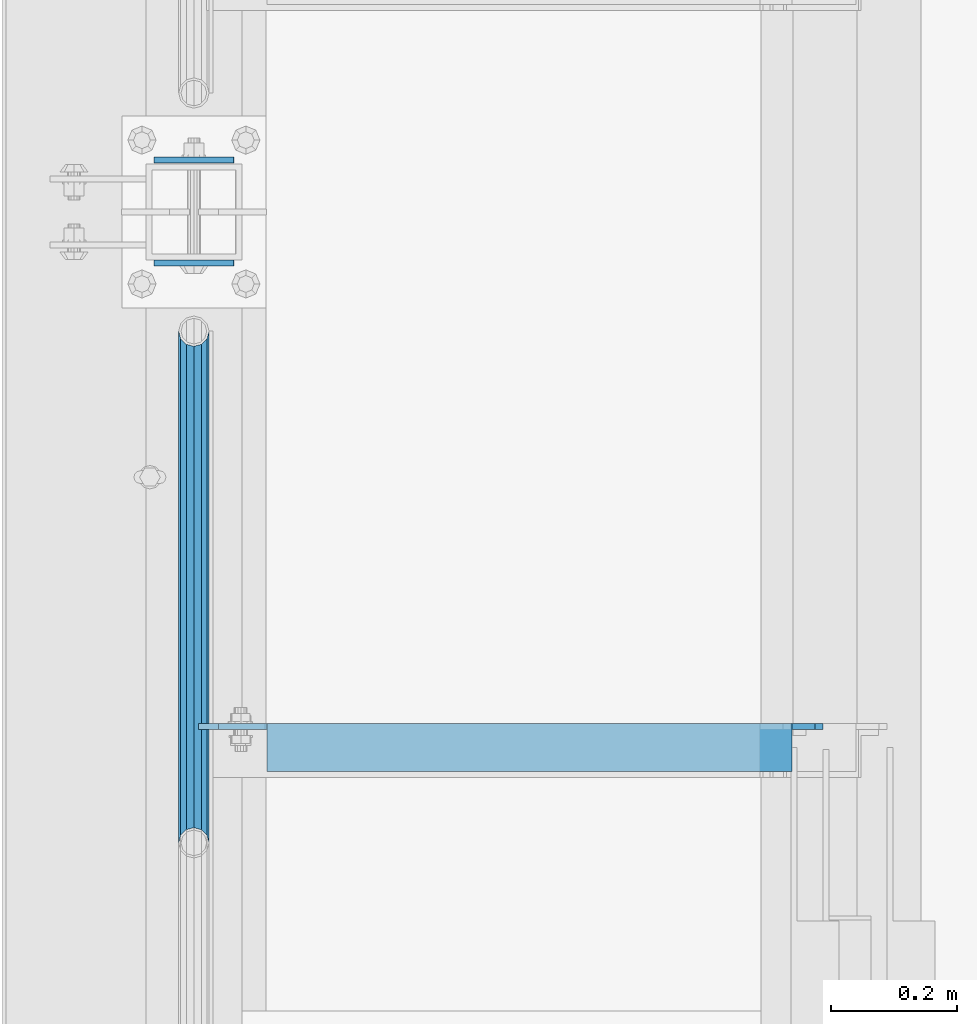
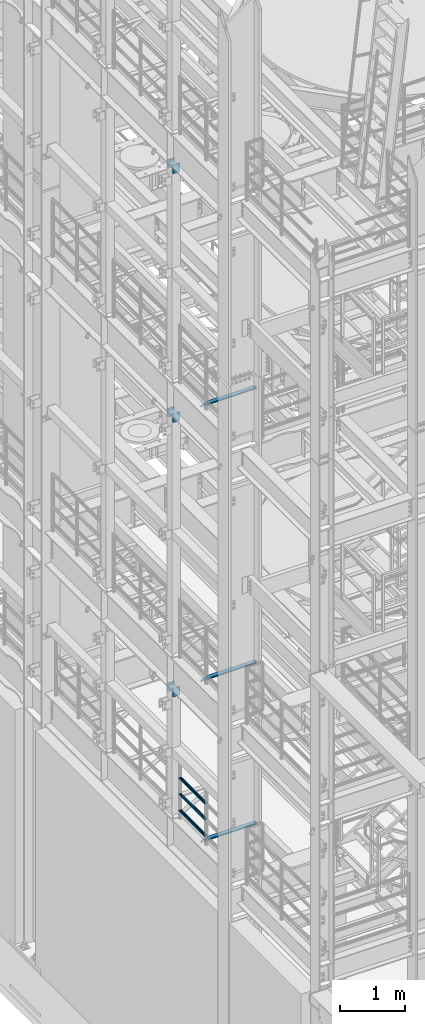
# One storey, part 1180 of 1876: 12 beams, 7 elements without a shape of their own.
"""IFC2X3 building model written with IfcOpenShell, lengths in millimetres."""

from ifc_helpers import new_model, si_unit, frame, origin_with_axes, place, context, subcontext, project, spatial, faceted_brep, material, type_object, element, aggregate, save


model = new_model("IFC2X3")

# Units and contexts
model_context = context("Model", 3, precision=1e-05, world=origin_with_axes())
body_context = subcontext(model_context, "Body", "Model", "MODEL_VIEW")
ifc_project = project(units=[si_unit("LENGTHUNIT", "METRE", prefix="MILLI"), si_unit("AREAUNIT", "SQUARE_METRE"), si_unit("VOLUMEUNIT", "CUBIC_METRE"), si_unit("MASSUNIT", "GRAM", prefix="KILO"), si_unit("TIMEUNIT", "SECOND"), si_unit("PLANEANGLEUNIT", "RADIAN"), si_unit("SOLIDANGLEUNIT", "STERADIAN"), si_unit("THERMODYNAMICTEMPERATUREUNIT", "DEGREE_CELSIUS"), si_unit("LUMINOUSINTENSITYUNIT", "LUMEN")], contexts=[model_context])

# Site, building, storey
site_placement = place(None, origin_with_axes())
site = spatial("IfcSite", under=ifc_project, at=site_placement, CompositionType="ELEMENT")
building_placement = place(site_placement, origin_with_axes())
building = spatial("IfcBuilding", under=site, at=building_placement, Name="Undefined", CompositionType="ELEMENT")
storey_placement = place(building_placement, origin_with_axes())
storey = spatial("IfcBuildingStorey", under=building, at=storey_placement, Name="Undefined", CompositionType="ELEMENT", Elevation=0.0)

# Assembly, beams
assembly_1_placement = place(storey_placement, origin_with_axes())
assembly_1 = element("IfcElementAssembly", 1, at=assembly_1_placement, inside=storey, Name="RAIL", AssemblyPlace="NOTDEFINED", PredefinedType="RIGID_FRAME")
ifc_material_1 = material()
beam_type_1 = type_object("IfcBeamType", Name="PIPE1-1/2SCH40", PredefinedType="NOTDEFINED")
beam_1_placement = place(assembly_1_placement, frame((5.37416779650463e-12, -2729.3062, 5292.725), z_axis=(0.0, 0.0, 1.0), x_axis=(0.0, -1.0, 0.0)))
beam_1 = element("IfcBeam", 2, at=beam_1_placement, type_object=beam_type_1, material=ifc_material_1, Name="RAIL", ObjectType="PIPE1-1/2SCH40", context=body_context, shape_type="Brep", body=[
    faceted_brep([(792.499707006684, -12.0649999999996, 20.8971929933177), (792.499707006684, -12.0650000000314, 15.8661214311469), (792.006278568813, -10.2235000000001, 17.7076214311819), (789.266900000001, -9.09494701772928e-13, 20.4470000000001), (789.266900000001, -9.09494701772928e-13, 24.130000000001), (792.00627856883, 10.2235000000001, 17.7076214311819), (792.499707006684, 12.0649999999678, 15.8661214312124), (792.499707006684, 12.0649999999996, 20.8971929933177), (813.396900000002, 24.1300000000001, 0.0), (801.331900000001, 20.8971929933186, 12.0649999999987), (801.331900000001, 20.8971929933186, -12.0649999999987), (798.142328437896, 17.7076214311801, 10.2235000000001), (800.881707006714, 20.4470000000001, 0.0), (798.142328437896, 17.7076214311801, -10.2235000000001), (792.499707006684, 12.0649999999678, -15.8661214312124), (792.499707006684, 12.0649999999996, -20.8971929933177), (792.00627856883, 10.2235000000001, -17.7076214311819), (789.266900000001, 0.0, -20.4470000000001), (789.266900000001, 0.0, -24.130000000001), (792.499707006684, -12.0650000000314, -15.8661214311469), (792.499707006684, -12.0649999999996, -20.8971929933177), (792.006278568813, -10.2235000000001, -17.7076214311819), (813.396900000002, -24.1300000000319, 0.0), (801.331900000001, -20.8971929933186, -12.0649999999987), (801.331900000001, -20.8971929933186, 12.0649999999987), (798.142328437831, -17.7076214311801, -10.2235000000001), (800.881707006651, -20.4470000000001, 0.0), (798.142328437831, -17.7076214311801, 10.2235000000001), (12.0650000000064, -20.8971929933177, -12.0649999999987), (20.8971929933249, -12.0650000000005, -20.8971929933177), (0.0, 24.1299999999992, 0.0), (12.0650000000064, 20.8971929933177, -12.0649999999987), (12.0650000000064, 20.8971929933177, 12.0649999999987), (20.8971929933249, 12.0650000000005, 20.8971929933177), (24.1300000000064, 0.0, 24.130000000001), (20.8971929933249, 12.0650000000005, -20.8971929933177), (24.1300000000063, 0.0, -24.130000000001), (24.1300000000063, 0.0, -20.4470000000001), (20.8971929933249, -12.0650000000005, -15.8661214311796), (21.3906214311868, -10.2235000000001, -17.7076214311819), (21.3906214311868, 10.2235000000001, -17.7076214311819), (20.8971929933249, 12.0650000000005, -15.8661214311796), (15.2545715621445, 17.7076214311801, -10.2235000000001), (12.5151929933249, 20.4470000000001, 0.0), (15.2545715621445, 17.7076214311801, 10.2235000000001), (20.8971929933249, 12.0650000000005, 15.8661214311796), (21.3906214311868, 10.2235000000001, 17.7076214311819), (24.1300000000064, 0.0, 20.4470000000001), (21.3906214311868, -10.2235000000001, 17.7076214311819), (20.8971929933249, -12.0650000000005, 15.8661214311796), (20.8971929933249, -12.0650000000005, 20.8971929933177), (12.0650000000064, -20.8971929933177, 12.0649999999987), (0.0, -24.1299999999992, 0.0), (15.2545715621445, -17.7076214311801, 10.2235000000001), (12.5151929933249, -20.4470000000001, 0.0), (15.2545715621445, -17.7076214311801, -10.2235000000001)], [[[0, 1, 2, 3, 4]], [[4, 3, 5, 6, 7]], [[8, 9, 10]], [[7, 6, 11, 12, 13, 14, 15, 10, 9]], [[16, 17, 18, 15, 14]], [[19, 20, 18, 17, 21]], [[22, 23, 24]], [[24, 23, 20, 19, 25, 26, 27, 1, 0]], [[28, 29, 20, 23]], [[30, 31, 32]], [[33, 34, 4, 7]], [[32, 33, 7, 9]], [[30, 32, 9, 8]], [[31, 30, 8, 10]], [[35, 31, 10, 15]], [[36, 35, 15, 18]], [[29, 36, 18, 20]], [[37, 36, 29, 38, 39]], [[40, 41, 35, 36, 37]], [[32, 31, 35, 41, 42, 43, 44, 45, 33]], [[33, 45, 46, 47, 34]], [[34, 47, 48, 49, 50]], [[34, 50, 0, 4]], [[50, 51, 24, 0]], [[51, 52, 22, 24]], [[52, 28, 23, 22]], [[51, 28, 52]], [[50, 49, 53, 54, 55, 38, 29, 28, 51]], [[55, 54, 26, 25]], [[21, 39, 38, 55, 25, 19]], [[37, 39, 21, 17]], [[40, 37, 17, 16]], [[42, 41, 40, 16, 14, 13]], [[43, 42, 13, 12]], [[44, 43, 12, 11]], [[5, 46, 45, 44, 11, 6]], [[47, 46, 5, 3]], [[48, 47, 3, 2]], [[53, 49, 48, 2, 1, 27]], [[54, 53, 27, 26]]]),
])
beam_2_placement = place(assembly_1_placement, frame((-1.81898940354586e-12, -3542.7031, 5597.525), z_axis=(0.0, 0.0, -1.0), x_axis=(0.0, 1.0, 0.0)))
beam_2 = element("IfcBeam", 3, at=beam_2_placement, type_object=beam_type_1, material=ifc_material_1, Name="RAIL", ObjectType="PIPE1-1/2SCH40", context=body_context, shape_type="Brep", body=[
    faceted_brep([(0.0, 24.1299999999992, 0.0), (12.0650000000064, 20.8971929933177, -12.0649999999987), (12.0650000000064, 20.8971929933177, 12.0649999999987), (12.0650000000064, -20.8971929933177, 12.0649999999987), (12.0650000000064, -20.8971929933177, -12.0649999999987), (0.0, -24.1299999999992, 0.0), (20.8971929933249, -12.0650000000005, 20.8971929933177), (20.8971929933249, -12.0650000000005, 15.8661214311796), (15.2545715621445, -17.7076214311801, 10.2235000000001), (12.5151929933249, -20.4470000000001, 0.0), (15.2545715621445, -17.7076214311801, -10.2235000000001), (20.8971929933249, -12.0650000000005, -15.8661214311796), (20.8971929933249, -12.0650000000005, -20.8971929933177), (24.1300000000063, 0.0, -20.4470000000001), (24.1300000000063, 0.0, -24.130000000001), (21.3906214311868, -10.2235000000001, -17.7076214311819), (21.3906214311868, 10.2235000000001, -17.7076214311819), (20.8971929933249, 12.0650000000005, -15.8661214311796), (20.8971929933249, 12.0650000000005, -20.8971929933177), (15.2545715621445, 17.7076214311801, -10.2235000000001), (12.5151929933249, 20.4470000000001, 0.0), (15.2545715621445, 17.7076214311801, 10.2235000000001), (20.8971929933249, 12.0650000000005, 15.8661214311796), (20.8971929933249, 12.0650000000005, 20.8971929933177), (21.3906214311868, 10.2235000000001, 17.7076214311819), (24.1300000000064, 0.0, 20.4470000000001), (24.1300000000064, 0.0, 24.130000000001), (21.3906214311868, -10.2235000000001, 17.7076214311819), (813.396900000002, 24.1300000000001, 0.0), (801.331900000001, 20.8971929933186, -12.0649999999987), (792.499707006684, 12.0649999999996, -20.8971929933177), (813.396900000002, -24.1300000000319, 0.0), (801.331900000001, -20.8971929933186, -12.0649999999987), (801.331900000001, -20.8971929933186, 12.0649999999987), (792.499707006684, -12.0649999999996, 20.8971929933177), (792.499707006684, -12.0649999999996, -20.8971929933177), (789.266900000001, 0.0, -24.130000000001), (792.00627856883, 10.2235000000001, -17.7076214311819), (789.266900000001, 0.0, -20.4470000000001), (792.499707006684, 12.0649999999678, -15.8661214312124), (792.499707006684, -12.0650000000314, -15.8661214311469), (792.006278568813, -10.2235000000001, -17.7076214311819), (798.142328437831, -17.7076214311801, -10.2235000000001), (800.881707006651, -20.4470000000001, 0.0), (798.142328437831, -17.7076214311801, 10.2235000000001), (792.499707006684, -12.0650000000314, 15.8661214311469), (792.006278568813, -10.2235000000001, 17.7076214311819), (789.266900000001, -9.09494701772928e-13, 20.4470000000001), (789.266900000001, -9.09494701772928e-13, 24.130000000001), (792.499707006684, 12.0649999999996, 20.8971929933177), (801.331900000001, 20.8971929933186, 12.0649999999987), (792.499707006684, 12.0649999999678, 15.8661214312124), (798.142328437896, 17.7076214311801, 10.2235000000001), (800.881707006714, 20.4470000000001, 0.0), (798.142328437896, 17.7076214311801, -10.2235000000001), (792.00627856883, 10.2235000000001, 17.7076214311819)], [[[0, 1, 2]], [[3, 4, 5]], [[6, 7, 8, 9, 10, 11, 12, 4, 3]], [[13, 14, 12, 11, 15]], [[16, 17, 18, 14, 13]], [[2, 1, 18, 17, 19, 20, 21, 22, 23]], [[23, 22, 24, 25, 26]], [[26, 25, 27, 7, 6]], [[1, 0, 28, 29]], [[18, 1, 29, 30]], [[31, 32, 33]], [[6, 3, 33, 34]], [[3, 5, 31, 33]], [[5, 4, 32, 31]], [[4, 12, 35, 32]], [[12, 14, 36, 35]], [[14, 18, 30, 36]], [[37, 38, 36, 30, 39]], [[40, 35, 36, 38, 41]], [[33, 32, 35, 40, 42, 43, 44, 45, 34]], [[34, 45, 46, 47, 48]], [[26, 6, 34, 48]], [[2, 23, 49, 50]], [[23, 26, 48, 49]], [[0, 2, 50, 28]], [[28, 50, 29]], [[49, 51, 52, 53, 54, 39, 30, 29, 50]], [[48, 47, 55, 51, 49]], [[25, 24, 55, 47]], [[55, 24, 22, 21, 52, 51]], [[21, 20, 53, 52]], [[20, 19, 54, 53]], [[19, 17, 16, 37, 39, 54]], [[16, 13, 38, 37]], [[13, 15, 41, 38]], [[41, 15, 11, 10, 42, 40]], [[10, 9, 43, 42]], [[9, 8, 44, 43]], [[8, 7, 27, 46, 45, 44]], [[27, 25, 47, 46]]]),
])
beam_3_placement = place(assembly_1_placement, frame((-1.81898940354586e-12, -3542.7031, 5902.325), z_axis=(0.0, 0.0, -1.0), x_axis=(0.0, 1.0, 0.0)))
beam_3 = element("IfcBeam", 4, at=beam_3_placement, type_object=beam_type_1, material=ifc_material_1, Name="RAIL", ObjectType="PIPE1-1/2SCH40", context=body_context, shape_type="Brep", body=[
    faceted_brep([(0.0, 24.1299999999992, 0.0), (12.0650000000064, 20.8971929933177, -12.0649999999987), (12.0650000000064, 20.8971929933177, 12.0649999999987), (12.0650000000064, -20.8971929933177, 12.0649999999987), (12.0650000000064, -20.8971929933177, -12.0649999999987), (0.0, -24.1299999999992, 0.0), (20.8971929933249, -12.0650000000005, 20.8971929933177), (20.8971929933249, -12.0650000000005, 15.8661214311796), (15.2545715621445, -17.7076214311801, 10.2235000000001), (12.5151929933249, -20.4470000000001, 0.0), (15.2545715621445, -17.7076214311801, -10.2235000000001), (20.8971929933249, -12.0650000000005, -15.8661214311796), (20.8971929933249, -12.0650000000005, -20.8971929933177), (24.1300000000063, 0.0, -20.4470000000001), (24.1300000000063, 0.0, -24.130000000001), (21.3906214311868, -10.2235000000001, -17.7076214311819), (21.3906214311868, 10.2235000000001, -17.7076214311819), (20.8971929933249, 12.0650000000005, -15.8661214311796), (20.8971929933249, 12.0650000000005, -20.8971929933177), (15.2545715621445, 17.7076214311801, -10.2235000000001), (12.5151929933249, 20.4470000000001, 0.0), (15.2545715621445, 17.7076214311801, 10.2235000000001), (20.8971929933249, 12.0650000000005, 15.8661214311796), (20.8971929933249, 12.0650000000005, 20.8971929933177), (21.3906214311868, 10.2235000000001, 17.7076214311819), (24.1300000000064, 0.0, 20.4470000000001), (24.1300000000064, 0.0, 24.130000000001), (21.3906214311868, -10.2235000000001, 17.7076214311819), (813.396900000002, 24.1300000000001, 0.0), (801.331900000001, 20.8971929933186, -12.0649999999987), (792.499707006684, 12.0649999999996, -20.8971929933177), (813.396900000002, -24.1300000000319, 0.0), (801.331900000001, -20.8971929933186, -12.0649999999987), (801.331900000001, -20.8971929933186, 12.0649999999987), (792.499707006684, -12.0649999999996, 20.8971929933177), (792.499707006684, -12.0649999999996, -20.8971929933177), (789.266900000001, 0.0, -24.130000000001), (792.00627856883, 10.2235000000001, -17.7076214311819), (789.266900000001, 0.0, -20.4470000000001), (792.499707006684, 12.0649999999678, -15.8661214312124), (792.499707006684, -12.0650000000314, -15.8661214311469), (792.006278568813, -10.2235000000001, -17.7076214311819), (798.142328437831, -17.7076214311801, -10.2235000000001), (800.881707006651, -20.4470000000001, 0.0), (798.142328437831, -17.7076214311801, 10.2235000000001), (792.499707006684, -12.0650000000314, 15.8661214311469), (792.006278568813, -10.2235000000001, 17.7076214311819), (789.266900000001, -9.09494701772928e-13, 20.4470000000001), (789.266900000001, -9.09494701772928e-13, 24.130000000001), (792.499707006684, 12.0649999999996, 20.8971929933177), (801.331900000001, 20.8971929933186, 12.0649999999987), (792.499707006684, 12.0649999999678, 15.8661214312124), (798.142328437896, 17.7076214311801, 10.2235000000001), (800.881707006714, 20.4470000000001, 0.0), (798.142328437896, 17.7076214311801, -10.2235000000001), (792.00627856883, 10.2235000000001, 17.7076214311819)], [[[0, 1, 2]], [[3, 4, 5]], [[6, 7, 8, 9, 10, 11, 12, 4, 3]], [[13, 14, 12, 11, 15]], [[16, 17, 18, 14, 13]], [[2, 1, 18, 17, 19, 20, 21, 22, 23]], [[23, 22, 24, 25, 26]], [[26, 25, 27, 7, 6]], [[1, 0, 28, 29]], [[18, 1, 29, 30]], [[31, 32, 33]], [[6, 3, 33, 34]], [[3, 5, 31, 33]], [[5, 4, 32, 31]], [[4, 12, 35, 32]], [[12, 14, 36, 35]], [[14, 18, 30, 36]], [[37, 38, 36, 30, 39]], [[40, 35, 36, 38, 41]], [[33, 32, 35, 40, 42, 43, 44, 45, 34]], [[34, 45, 46, 47, 48]], [[26, 6, 34, 48]], [[2, 23, 49, 50]], [[23, 26, 48, 49]], [[0, 2, 50, 28]], [[28, 50, 29]], [[49, 51, 52, 53, 54, 39, 30, 29, 50]], [[48, 47, 55, 51, 49]], [[25, 24, 55, 47]], [[55, 24, 22, 21, 52, 51]], [[21, 20, 53, 52]], [[20, 19, 54, 53]], [[19, 17, 16, 37, 39, 54]], [[16, 13, 38, 37]], [[13, 15, 41, 38]], [[41, 15, 11, 10, 42, 40]], [[10, 9, 43, 42]], [[9, 8, 44, 43]], [[8, 7, 27, 46, 45, 44]], [[27, 25, 47, 46]]]),
])
aggregate(assembly_1, [beam_1, beam_2, beam_3])

assembly_2_placement = place(storey_placement, origin_with_axes())
assembly_2 = element("IfcElementAssembly", 5, at=assembly_2_placement, inside=storey, Name="BEAM", AssemblyPlace="NOTDEFINED", PredefinedType="RIGID_FRAME")
ifc_material_2 = material(Name="STEEL/A36")
beam_type_2 = type_object("IfcBeamType", PredefinedType="NOTDEFINED")
beam_4_placement = place(assembly_2_placement, frame((-63.6296757345187, -2457.45, 7448.54714244377), z_axis=(5.59490000219896e-05, 0.0, -0.999999998434855), x_axis=(0.999999998434855, 0.0, 5.59490000219868e-05)))
beam_4 = element("IfcBeam", 6, at=beam_4_placement, type_object=beam_type_2, material=ifc_material_2, Name="PLATE", context=body_context, shape_type="Brep", body=[
    faceted_brep([(0.0, 4.76249999999982, -82.5499999999993), (0.0, 4.76249999999982, 82.5499999999993), (127.0, 4.76249999999982, 82.5499999999993), (127.0, 4.76249999999982, -82.5499999999993), (0.0, -4.76249999999982, 82.5499999999993), (127.0, -4.76249999999982, 82.5499999999993), (0.0, -4.76249999999982, -82.5499999999993), (127.0, -4.76249999999982, -82.5499999999993)], [[[0, 1, 2, 3]], [[1, 4, 5, 2]], [[4, 6, 7, 5]], [[6, 0, 3, 7]], [[5, 7, 3, 2]], [[6, 4, 1, 0]]]),
])
beam_5_placement = place(assembly_2_placement, frame((-63.6296757345187, -2620.9625, 7448.54714244377), z_axis=(5.59490000219896e-05, 0.0, -0.999999998434855), x_axis=(0.999999998434855, 0.0, 5.59490000219868e-05)))
beam_5 = element("IfcBeam", 7, at=beam_5_placement, type_object=beam_type_2, material=ifc_material_2, Name="PLATE", context=body_context, shape_type="Brep", body=[
    faceted_brep([(0.0, 4.76249999999982, -82.5499999999993), (0.0, 4.76249999999982, 82.5499999999993), (127.0, 4.76249999999982, 82.5499999999993), (127.0, 4.76249999999982, -82.5499999999993), (0.0, -4.76249999999982, 82.5499999999993), (127.0, -4.76249999999982, 82.5499999999993), (0.0, -4.76249999999982, -82.5499999999993), (127.0, -4.76249999999982, -82.5499999999993)], [[[0, 1, 2, 3]], [[1, 4, 5, 2]], [[4, 6, 7, 5]], [[6, 0, 3, 7]], [[5, 7, 3, 2]], [[6, 4, 1, 0]]]),
])
aggregate(assembly_2, [beam_4, beam_5])

assembly_3_placement = place(storey_placement, origin_with_axes())
assembly_3 = element("IfcElementAssembly", 8, at=assembly_3_placement, inside=storey, Name="BEAM", AssemblyPlace="NOTDEFINED", PredefinedType="RIGID_FRAME")
beam_6_placement = place(assembly_3_placement, frame((-63.6315195800257, -2457.45, 12604.7488224823), z_axis=(2.95459999824743e-05, 0.0, -0.999999999563517), x_axis=(0.999999999563517, 0.0, 2.95459999828704e-05)))
beam_6 = element("IfcBeam", 9, at=beam_6_placement, type_object=beam_type_2, material=ifc_material_2, Name="PLATE", context=body_context, shape_type="Brep", body=[
    faceted_brep([(0.0, 4.76249999999982, -82.5499999999993), (0.0, 4.76249999999982, 82.5499999999993), (127.0, 4.76249999999982, 82.5499999999993), (127.0, 4.76249999999982, -82.5499999999993), (0.0, -4.76249999999982, 82.5499999999993), (127.0, -4.76249999999982, 82.5499999999993), (0.0, -4.76249999999982, -82.5499999999993), (127.0, -4.76249999999982, -82.5499999999993)], [[[0, 1, 2, 3]], [[1, 4, 5, 2]], [[4, 6, 7, 5]], [[6, 0, 3, 7]], [[5, 7, 3, 2]], [[6, 4, 1, 0]]]),
])
beam_7_placement = place(assembly_3_placement, frame((-63.6315195800257, -2620.9625, 12604.7488224823), z_axis=(2.95459999824743e-05, 0.0, -0.999999999563517), x_axis=(0.999999999563517, 0.0, 2.95459999828704e-05)))
beam_7 = element("IfcBeam", 10, at=beam_7_placement, type_object=beam_type_2, material=ifc_material_2, Name="PLATE", context=body_context, shape_type="Brep", body=[
    faceted_brep([(0.0, 4.76249999999982, -82.5499999999993), (0.0, 4.76249999999982, 82.5499999999993), (127.0, 4.76249999999982, 82.5499999999993), (127.0, 4.76249999999982, -82.5499999999993), (0.0, -4.76249999999982, 82.5499999999993), (127.0, -4.76249999999982, 82.5499999999993), (0.0, -4.76249999999982, -82.5499999999993), (127.0, -4.76249999999982, -82.5499999999993)], [[[0, 1, 2, 3]], [[1, 4, 5, 2]], [[4, 6, 7, 5]], [[6, 0, 3, 7]], [[5, 7, 3, 2]], [[6, 4, 1, 0]]]),
])
aggregate(assembly_3, [beam_6, beam_7])

assembly_4_placement = place(storey_placement, origin_with_axes())
assembly_4 = element("IfcElementAssembly", 11, at=assembly_4_placement, inside=storey, Name="BEAM", AssemblyPlace="NOTDEFINED", PredefinedType="RIGID_FRAME")
beam_8_placement = place(assembly_4_placement, frame((-63.5, -2457.45, 17278.35), z_axis=(0.0, 0.0, -1.0), x_axis=(1.0, 0.0, 0.0)))
beam_8 = element("IfcBeam", 12, at=beam_8_placement, type_object=beam_type_2, material=ifc_material_2, Name="PLATE", context=body_context, shape_type="Brep", body=[
    faceted_brep([(0.0, 4.76249999999982, -82.5499999999993), (0.0, 4.76249999999982, 82.5499999999993), (127.0, 4.76249999999982, 82.5499999999993), (127.0, 4.76249999999982, -82.5499999999993), (0.0, -4.76249999999982, 82.5499999999993), (127.0, -4.76249999999982, 82.5499999999993), (0.0, -4.76249999999982, -82.5499999999993), (127.0, -4.76249999999982, -82.5499999999993)], [[[0, 1, 2, 3]], [[1, 4, 5, 2]], [[4, 6, 7, 5]], [[6, 0, 3, 7]], [[5, 7, 3, 2]], [[6, 4, 1, 0]]]),
])
beam_9_placement = place(assembly_4_placement, frame((-63.5, -2620.9625, 17278.35), z_axis=(0.0, 0.0, -1.0), x_axis=(1.0, 0.0, 0.0)))
beam_9 = element("IfcBeam", 13, at=beam_9_placement, type_object=beam_type_2, material=ifc_material_2, Name="PLATE", context=body_context, shape_type="Brep", body=[
    faceted_brep([(0.0, 4.76249999999982, -82.5499999999993), (0.0, 4.76249999999982, 82.5499999999993), (127.0, 4.76249999999982, 82.5499999999993), (127.0, 4.76249999999982, -82.5499999999993), (0.0, -4.76249999999982, 82.5499999999993), (127.0, -4.76249999999982, 82.5499999999993), (0.0, -4.76249999999982, -82.5499999999993), (127.0, -4.76249999999982, -82.5499999999993)], [[[0, 1, 2, 3]], [[1, 4, 5, 2]], [[4, 6, 7, 5]], [[6, 0, 3, 7]], [[5, 7, 3, 2]], [[6, 4, 1, 0]]]),
])
aggregate(assembly_4, [beam_8, beam_9])

# Assembly, beam
assembly_5_placement = place(storey_placement, origin_with_axes())
assembly_5 = element("IfcElementAssembly", 14, at=assembly_5_placement, inside=storey, Name="ANGLE", AssemblyPlace="NOTDEFINED", PredefinedType="RIGID_FRAME")
beam_type_3 = type_object("IfcBeamType", Name="L3X3X3/8", PredefinedType="NOTDEFINED")
beam_10_placement = place(assembly_5_placement, frame((0.0, -3390.9, 8115.3), z_axis=(0.0, -1.0, 0.0), x_axis=(1.0, 0.0, 0.0)))
beam_10 = element("IfcBeam", 15, at=beam_10_placement, type_object=beam_type_3, material=ifc_material_2, Name="ANGLE", ObjectType="L3X3X3/8", context=body_context, shape_type="Brep", body=[
    faceted_brep([(115.886999817316, 28.5750000000007, 38.0999999999999), (115.886999817316, 38.0999999999985, 38.0999999999999), (115.886998826692, 38.0999999999985, -38.0999999999999), (115.88699882669, 12.699999237062, -38.0999999999999), (115.886998950515, 12.699999237062, -28.5749999999998), (115.88699895052, 28.5750000000007, -28.5749999999998), (38.8937432114558, 12.699999237062, -38.0999999999999), (38.8937433352807, 12.699999237062, -28.5749999999998), (7.14374321145577, -19.050000762938, -38.0999999999999), (7.14374333528067, -19.050000762938, -28.5749999999998), (7.1437499954859, -38.0999999999985, -38.0999999999999), (7.1437499954859, -38.0999999999985, -28.5749999999998), (1000.12500242412, 15.8750003814712, -28.5749999999998), (987.425002614851, 28.5749999999998, -28.5749999999998), (950.913000303442, 28.5749999999998, -28.5749999999998), (1000.12500001551, -38.1000000000004, -28.5749999999998), (1000.12500242412, 3.17500152588036, -28.5749999999998), (950.913001170238, 28.5749999999998, 38.0999999999999), (950.913001170238, 38.1000000000004, 38.0999999999999), (950.913000179614, 38.1000000000004, -38.0999999999999), (950.913000366403, 28.5750001907363, -38.0999999999999), (987.425002357675, 28.5750001907363, -38.0999999999999), (1000.12500216694, 15.8750003814712, -38.0999999999999), (1000.12500216694, 3.17500152588036, -38.0999999999999), (1000.12500001551, -38.1000000000004, -38.0999999999999)], [[[0, 1, 2, 3, 4, 5]], [[4, 3, 6, 7]], [[7, 6, 8, 9]], [[8, 10, 11, 9]], [[12, 13, 14, 5, 4, 7, 9, 11, 15, 16]], [[0, 5, 14, 17]], [[1, 0, 17, 18]], [[2, 1, 18, 19]], [[17, 14, 20, 19, 18]], [[13, 21, 20, 14]], [[12, 22, 21, 13]], [[16, 23, 22, 12]], [[10, 8, 6, 3, 2, 19, 20, 21, 22, 23, 24]], [[11, 10, 24, 15]], [[23, 16, 15, 24]]]),
])
aggregate(assembly_5, [beam_10])

assembly_6_placement = place(storey_placement, origin_with_axes())
assembly_6 = element("IfcElementAssembly", 16, at=assembly_6_placement, inside=storey, Name="ANGLE", AssemblyPlace="NOTDEFINED", PredefinedType="RIGID_FRAME")
beam_11_placement = place(assembly_6_placement, frame((0.0, -3390.9, 5092.7), z_axis=(0.0, -1.0, 0.0), x_axis=(1.0, 0.0, 0.0)))
beam_11 = element("IfcBeam", 17, at=beam_11_placement, type_object=beam_type_3, material=ifc_material_2, Name="ANGLE", ObjectType="L3X3X3/8", context=body_context, shape_type="Brep", body=[
    faceted_brep([(115.886999817316, 28.5750000000007, 38.0999999999999), (115.886999817316, 38.0999999999985, 38.0999999999999), (115.886998826692, 38.0999999999985, -38.0999999999999), (115.88699882669, 12.699999237062, -38.0999999999999), (115.886998950515, 12.699999237062, -28.5749999999998), (115.88699895052, 28.5750000000007, -28.5749999999998), (38.8937432114558, 12.699999237062, -38.0999999999999), (38.8937433352807, 12.699999237062, -28.5749999999998), (7.14374321145577, -19.050000762938, -38.0999999999999), (7.14374333528067, -19.050000762938, -28.5749999999998), (7.1437499954859, -38.0999999999985, -38.0999999999999), (7.1437499954859, -38.0999999999985, -28.5749999999998), (1000.12500242412, 15.8750003814712, -28.5749999999998), (987.425002614851, 28.5749999999998, -28.5749999999998), (950.913000303442, 28.5749999999998, -28.5749999999998), (1000.12500001551, -38.1000000000004, -28.5749999999998), (1000.12500242412, 3.17500152588036, -28.5749999999998), (950.913001170238, 28.5749999999998, 38.0999999999999), (950.913001170238, 38.1000000000004, 38.0999999999999), (950.913000179614, 38.1000000000004, -38.0999999999999), (950.913000366403, 28.5750001907363, -38.0999999999999), (987.425002357675, 28.5750001907363, -38.0999999999999), (1000.12500216694, 15.8750003814712, -38.0999999999999), (1000.12500216694, 3.17500152588036, -38.0999999999999), (1000.12500001551, -38.1000000000004, -38.0999999999999)], [[[0, 1, 2, 3, 4, 5]], [[4, 3, 6, 7]], [[7, 6, 8, 9]], [[8, 10, 11, 9]], [[12, 13, 14, 5, 4, 7, 9, 11, 15, 16]], [[0, 5, 14, 17]], [[1, 0, 17, 18]], [[2, 1, 18, 19]], [[17, 14, 20, 19, 18]], [[13, 21, 20, 14]], [[12, 22, 21, 13]], [[16, 23, 22, 12]], [[10, 8, 6, 3, 2, 19, 20, 21, 22, 23, 24]], [[11, 10, 24, 15]], [[23, 16, 15, 24]]]),
])
aggregate(assembly_6, [beam_11])

assembly_7_placement = place(storey_placement, origin_with_axes())
assembly_7 = element("IfcElementAssembly", 18, at=assembly_7_placement, inside=storey, Name="ANGLE", AssemblyPlace="NOTDEFINED", PredefinedType="RIGID_FRAME")
beam_12_placement = place(assembly_7_placement, frame((-1.57146639077011e-08, -3390.9, 13271.5), z_axis=(0.0, -1.0, 0.0), x_axis=(1.0, 0.0, 0.0)))
beam_12 = element("IfcBeam", 19, at=beam_12_placement, type_object=beam_type_3, material=ifc_material_2, Name="ANGLE", ObjectType="L3X3X3/8", context=body_context, shape_type="Brep", body=[
    faceted_brep([(115.886999817316, 28.5750000000007, 38.0999999999999), (115.886999817316, 38.0999999999985, 38.0999999999999), (115.886998826692, 38.0999999999985, -38.0999999999999), (115.88699882669, 12.699999237062, -38.0999999999999), (115.886998950515, 12.699999237062, -28.5749999999998), (115.88699895052, 28.5750000000007, -28.5749999999998), (38.8937432114558, 12.699999237062, -38.0999999999999), (38.8937433352807, 12.699999237062, -28.5749999999998), (7.14374321145577, -19.050000762938, -38.0999999999999), (7.14374333528067, -19.050000762938, -28.5749999999998), (7.1437499954859, -38.0999999999985, -38.0999999999999), (7.1437499954859, -38.0999999999985, -28.5749999999998), (1000.12500243948, 14.2880004882809, -28.5749999999998), (987.425002630213, 26.988000297546, -28.5749999999998), (950.913000638941, 26.988000297546, -28.5749999999998), (950.913000303442, 28.5749999999998, -28.5749999999998), (1000.12500001551, -38.1000000000004, -28.5749999999998), (1000.12500243948, 1.58799972534143, -28.5749999999998), (950.913001170238, 28.5749999999998, 38.0999999999999), (950.913001170238, 38.1000000000004, 38.0999999999999), (950.913000179614, 38.1000000000004, -38.0999999999999), (950.913000381765, 26.988000297546, -38.0999999999999), (987.425002373037, 26.988000297546, -38.0999999999999), (1000.1250021823, 14.2880004882809, -38.0999999999999), (1000.1250021823, 1.58799972534143, -38.0999999999999), (1000.12500001551, -38.1000000000004, -38.0999999999999)], [[[0, 1, 2, 3, 4, 5]], [[4, 3, 6, 7]], [[7, 6, 8, 9]], [[8, 10, 11, 9]], [[12, 13, 14, 15, 5, 4, 7, 9, 11, 16, 17]], [[0, 5, 15, 18]], [[1, 0, 18, 19]], [[2, 1, 19, 20]], [[18, 15, 14, 21, 20, 19]], [[13, 22, 21, 14]], [[12, 23, 22, 13]], [[17, 24, 23, 12]], [[10, 8, 6, 3, 2, 20, 21, 22, 23, 24, 25]], [[11, 10, 25, 16]], [[24, 17, 16, 25]]]),
])
aggregate(assembly_7, [beam_12])

save(model, "model.ifc")
